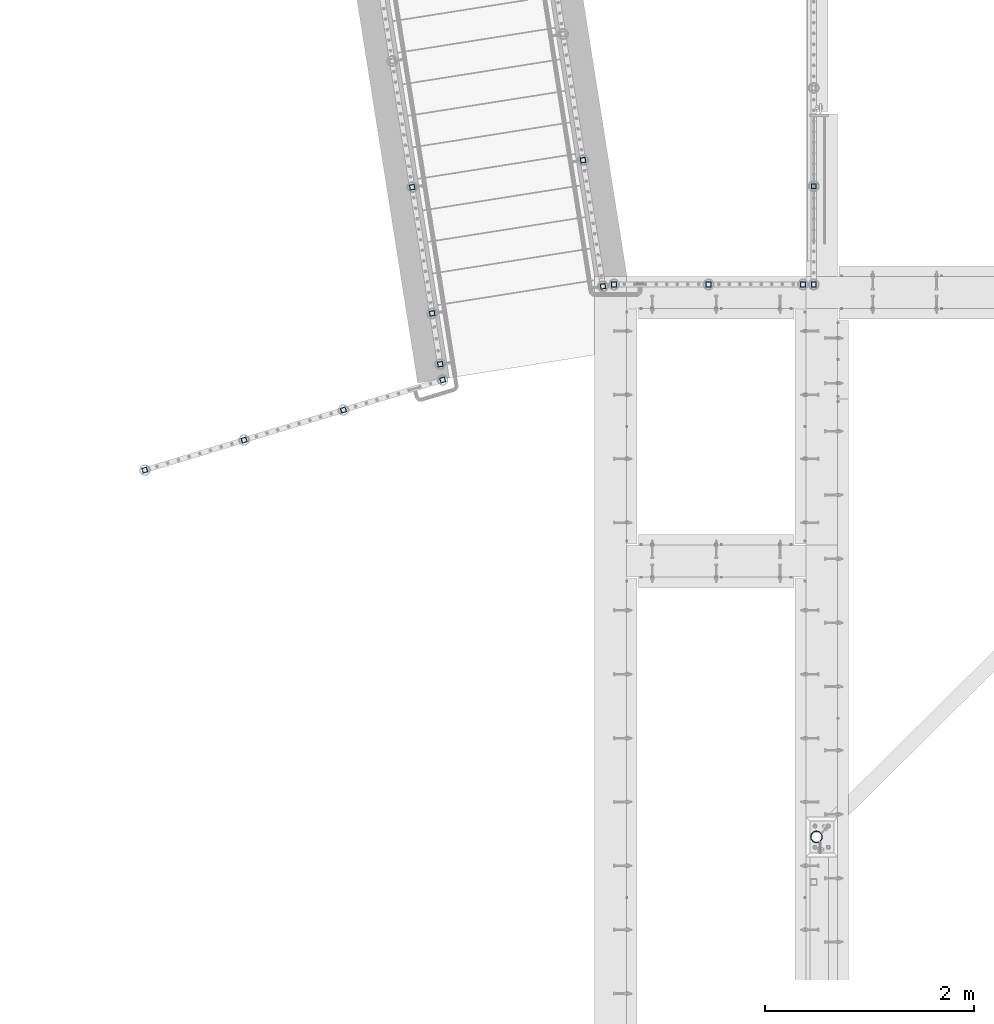
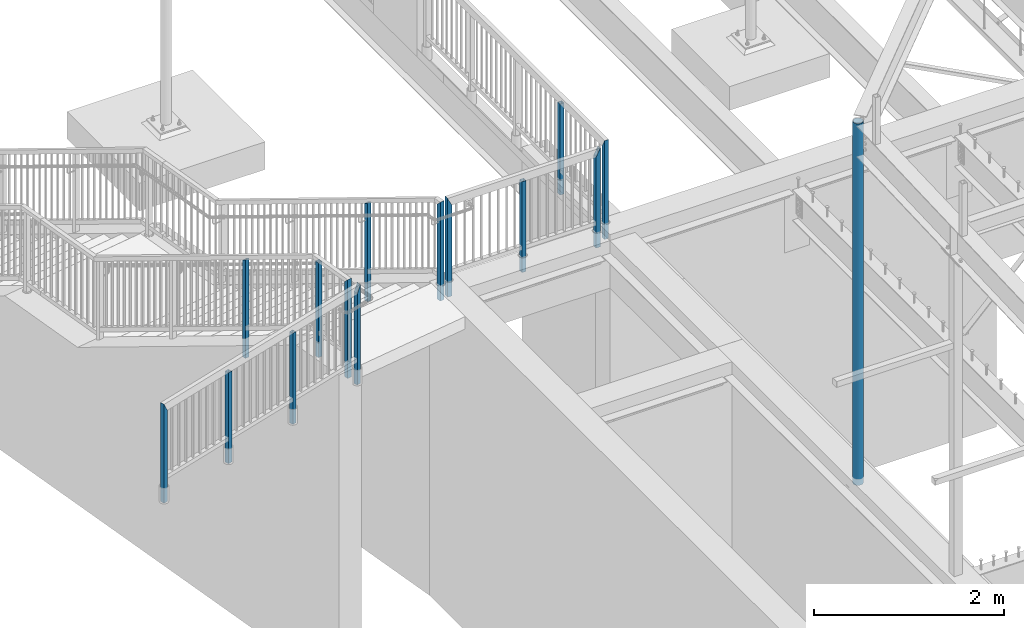
# One storey, part 124 of 975: 15 columns.
"""IFC2X3 building model written with IfcOpenShell, lengths in millimetres."""

import ifcopenshell
import ifcopenshell.guid

model = None  # the IFC model being written
_history = None  # IfcOwnerHistory: only IFC2X3 demands one
_inside = {}  # id of a spatial element -> (the spatial element, [elements in it])
_under = {}  # id of a project, library or spatial element -> (it, [spatial elements below it])
_declared = {}  # id of a project -> (the project, [libraries it declares])
_typed = {}  # id of a type object -> (the type object, [elements of that type])
_made_of = {}  # id of a material, layer set ... -> (it, [elements and type objects made of it])


def new_model(schema):
    """Start an empty IFC model of exactly this schema.

    Asked for "IFC4X3", IfcOpenShell would pick the latest addendum, in which some entities
    have other attributes; the version numbers below select the first issue.
    IFC2X3 requires an IfcOwnerHistory on every rooted entity: one is made here for all.
    """
    global model, _history
    if schema == "IFC4X3":
        model = ifcopenshell.file(schema_version=(4, 3, 0, 0))
    else:
        model = ifcopenshell.file(schema=schema)
    _inside.clear()
    _under.clear()
    _declared.clear()
    _typed.clear()
    _made_of.clear()
    _history = None
    if model.schema == "IFC2X3":
        org = make("IfcOrganization", Name="unknown")
        user = make(
            "IfcPersonAndOrganization",
            ThePerson=make("IfcPerson", FamilyName="unknown"),
            TheOrganization=org,
        )
        app = make(
            "IfcApplication",
            ApplicationDeveloper=org,
            Version="unknown",
            ApplicationFullName="unknown",
            ApplicationIdentifier="unknown",
        )
        _history = make(
            "IfcOwnerHistory",
            OwningUser=user,
            OwningApplication=app,
            ChangeAction="ADDED",
            CreationDate=0,
        )
    return model


def make(cls, **values):
    """One entity of the class cls with the attributes given. An attribute that is None is left unset."""
    return model.create_entity(
        cls, **{name: value for name, value in values.items() if value is not None}
    )


def rooted(cls, **values):
    """An entity with a GlobalId (a new one), such as an element, a storey or a relation."""
    return make(cls, GlobalId=ifcopenshell.guid.new(), OwnerHistory=_history, **values)


def si_unit(unit_type, name, prefix=None):
    """IfcSIUnit, for example si_unit("LENGTHUNIT", "METRE", prefix="MILLI")."""
    return make("IfcSIUnit", UnitType=unit_type, Prefix=prefix, Name=name)


def assignment(units):
    """IfcUnitAssignment: the units of a project."""
    return None if units is None else make("IfcUnitAssignment", Units=units)


def point(xyz):
    """IfcCartesianPoint."""
    return None if xyz is None else make("IfcCartesianPoint", Coordinates=xyz)


def direction(xyz):
    """IfcDirection."""
    return None if xyz is None else make("IfcDirection", DirectionRatios=xyz)


def frame(location, z_axis=None, x_axis=None):
    """IfcAxis2Placement3D, a coordinate frame: its origin and axes. An axis left out is left unset."""
    return make(
        "IfcAxis2Placement3D",
        Location=point(location),
        Axis=direction(z_axis),
        RefDirection=direction(x_axis),
    )


def origin_with_axes():
    """The frame at (0, 0, 0) with the z axis (0, 0, 1) and the x axis (1, 0, 0) written out."""
    return frame((0.0, 0.0, 0.0), z_axis=(0.0, 0.0, 1.0), x_axis=(1.0, 0.0, 0.0))


def place(relative_to, where):
    """IfcLocalPlacement: puts the frame where relative to a parent placement (None: the world)."""
    return make(
        "IfcLocalPlacement", PlacementRelTo=relative_to, RelativePlacement=where
    )


def context(
    kind, dimensions, precision=None, world=None, true_north=None, identifier=None
):
    """IfcGeometricRepresentationContext, for example the 3D "Model" context."""
    return make(
        "IfcGeometricRepresentationContext",
        ContextIdentifier=identifier,
        ContextType=kind,
        CoordinateSpaceDimension=dimensions,
        Precision=precision,
        WorldCoordinateSystem=world,
        TrueNorth=true_north,
    )


def subcontext(parent, identifier, kind, view, scale=None):
    """IfcGeometricRepresentationSubContext, for example "Body" below "Model"."""
    return make(
        "IfcGeometricRepresentationSubContext",
        ContextIdentifier=identifier,
        ContextType=kind,
        ParentContext=parent,
        TargetScale=scale,
        TargetView=view,
    )


def project(units=None, contexts=None):
    """IfcProject with its units and contexts."""
    return rooted(
        "IfcProject",
        Name="project",
        RepresentationContexts=contexts,
        UnitsInContext=assignment(units),
    )


def spatial(cls, under=None, at=None, **own):
    """A site, building, storey or space (cls), placed at a placement, below another one or the project."""
    s = rooted(cls, ObjectPlacement=at, **own)
    if under is not None:
        _under.setdefault(under.id(), (under, []))[1].append(s)
    return s


def faces_of(points, faces, orient=None, outer=None):
    """IfcFace entities. A face is a list of loops; a loop is a list of indices into points, from 0.

    orient and outer hold one flag for each loop. By default every Orientation is true, the
    first loop of a face is its IfcFaceOuterBound and the others are IfcFaceBound.
    """
    made = []
    for i, loops in enumerate(faces):
        bounds = []
        for j, loop in enumerate(loops):
            is_outer = j == 0 if outer is None else outer[i][j]
            bounds.append(
                make(
                    "IfcFaceOuterBound" if is_outer else "IfcFaceBound",
                    Bound=make("IfcPolyLoop", Polygon=[points[k] for k in loop]),
                    Orientation=True if orient is None else orient[i][j],
                )
            )
        made.append(make("IfcFace", Bounds=bounds))
    return made


def faceted_brep(points, faces, orient=None, outer=None, voids=None):
    """IfcFacetedBrep: a solid bounded by flat faces; with voids (closed shells), ...WithVoids."""
    shared = [point(p) for p in points]
    hull = make("IfcClosedShell", CfsFaces=faces_of(shared, faces, orient, outer))
    if voids is None:
        return make("IfcFacetedBrep", Outer=hull)
    return make(
        "IfcFacetedBrepWithVoids",
        Outer=hull,
        Voids=[
            make(cls, CfsFaces=faces_of(shared, fs, o, b)) for cls, fs, o, b in voids
        ],
    )


def shape(context_of_items, identifier, shape_type, items):
    """IfcShapeRepresentation: the items that make up one representation, for example the "Body"."""
    return make(
        "IfcShapeRepresentation",
        ContextOfItems=context_of_items,
        RepresentationIdentifier=identifier,
        RepresentationType=shape_type,
        Items=items,
    )


def material(Name=None, Category=None):
    """IfcMaterial."""
    return make("IfcMaterial", Name=Name, Category=Category)


def made_of(thing, what):
    """Note that an element or type object is made of a material, layer set ...; save() writes the relation."""
    if what is not None:
        _made_of.setdefault(what.id(), (what, []))[1].append(thing)
    return thing


def type_object(cls, material=None, **own):
    """A type object (cls), such as IfcWallType, which elements share."""
    return made_of(rooted(cls, **own), material)


def element(
    cls,
    number,
    at=None,
    inside=None,
    cuts=None,
    type_object=None,
    material=None,
    context=None,
    identifier="Body",
    shape_type=None,
    held_by="IfcProductDefinitionShape",
    body=None,
    shapes=None,
    **own,
):
    """One element of the class cls, such as IfcWall. Its Tag is "e" and its number.

    at: its placement. inside: the storey or other place that contains it. cuts: it is an
    opening in that element (IfcRelVoidsElement). A single representation is given by context,
    identifier, shape_type and body (its items); several are given by shapes. held_by: the class
    of the entity that holds the representations. save() writes the other relations.
    """
    e = rooted(cls, Tag="e%d" % number, ObjectPlacement=at, **own)
    if body is not None:
        shapes = [shape(context, identifier, shape_type, body)]
    if shapes is not None:
        e.Representation = make(held_by, Representations=shapes)
    if inside is not None:
        _inside.setdefault(inside.id(), (inside, []))[1].append(e)
    if cuts is not None:
        rooted(
            "IfcRelVoidsElement", RelatingBuildingElement=cuts, RelatedOpeningElement=e
        )
    if type_object is not None:
        _typed.setdefault(type_object.id(), (type_object, []))[1].append(e)
    return made_of(e, material)


def aggregate(whole, parts):
    """IfcRelAggregates: a whole, such as a stair, and the parts it consists of."""
    return rooted("IfcRelAggregates", RelatingObject=whole, RelatedObjects=parts)


def save(model, path):
    """Write the relations noted so far, then the file.

    IfcRelAggregates (storeys below a building ...), IfcRelContainedInSpatialStructure (elements
    in a storey), IfcRelDefinesByType, IfcRelAssociatesMaterial and IfcRelDeclares: one each for
    every whole, place, type object, material and project.
    """
    for whole, parts in _under.values():
        aggregate(whole, parts)
    for where, things in _inside.values():
        rooted(
            "IfcRelContainedInSpatialStructure",
            RelatedElements=things,
            RelatingStructure=where,
        )
    for kind, things in _typed.values():
        rooted("IfcRelDefinesByType", RelatedObjects=things, RelatingType=kind)
    for what, things in _made_of.values():
        rooted("IfcRelAssociatesMaterial", RelatedObjects=things, RelatingMaterial=what)
    for by, libraries in _declared.values():
        rooted("IfcRelDeclares", RelatingContext=by, RelatedDefinitions=libraries)
    model.write(path)


model = new_model("IFC2X3")

# Units and contexts
model_context = context("Model", 3, precision=1e-05, world=origin_with_axes())
body_context = subcontext(model_context, "Body", "Model", "MODEL_VIEW")
ifc_project = project(units=[si_unit("LENGTHUNIT", "METRE", prefix="MILLI"), si_unit("AREAUNIT", "SQUARE_METRE"), si_unit("VOLUMEUNIT", "CUBIC_METRE"), si_unit("MASSUNIT", "GRAM", prefix="KILO"), si_unit("TIMEUNIT", "SECOND"), si_unit("PLANEANGLEUNIT", "RADIAN"), si_unit("SOLIDANGLEUNIT", "STERADIAN"), si_unit("THERMODYNAMICTEMPERATUREUNIT", "DEGREE_CELSIUS"), si_unit("LUMINOUSINTENSITYUNIT", "LUMEN")], contexts=[model_context])

# Site, building, storey
site_placement = place(None, origin_with_axes())
site = spatial("IfcSite", under=ifc_project, at=site_placement, CompositionType="ELEMENT")
building_placement = place(site_placement, origin_with_axes())
building = spatial("IfcBuilding", under=site, at=building_placement, Name="Undefined", CompositionType="ELEMENT")
storey_placement = place(building_placement, origin_with_axes())
storey = spatial("IfcBuildingStorey", under=building, at=storey_placement, Name="Undefined", CompositionType="ELEMENT", Elevation=0.0)

# Columns
ifc_material_1 = material()
column_type_1 = type_object("IfcColumnType", Name="HSS2X2X.188_TUBES", PredefinedType="NOTDEFINED")
column_1_placement = place(storey_placement, frame((-1474.06692255113, 19910.997122319, 3835.40003518347), z_axis=(-0.987688340611262, -0.156434464938429, 0.0), x_axis=(0.0, 0.0, 1.0)))
element("IfcColumn", 1, at=column_1_placement, inside=storey, type_object=column_type_1, material=ifc_material_1, Name="HANDRAIL", ObjectType="HSS2X2X.188_TUBES", context=body_context, shape_type="Brep", body=[
    faceted_brep([(0.0, 20.6374999999753, -20.6375000000298), (0.0, -20.6375000000153, -20.6375000000153), (1265.23743975856, -20.6374999999971, -20.6374999999985), (1223.96244713993, 20.6374999999716, -20.6374999999923), (0.0, -20.6374999999825, 20.6375000000335), (1265.23744318539, -20.637499999968, 20.6374999999925), (0.0, 20.6375000000116, 20.6375000000189), (1223.96245056676, 20.6374999999971, 20.6374999999994), (0.0, 25.3999999999724, -25.4000000000342), (0.0, 25.400000000016, 25.4000000000196), (1219.19999999993, 25.400000000016, 25.4000000000196), (1219.19994759622, 25.3999999999651, -25.3999999999905), (0.0, -25.399999999976, 25.4000000000378), (1269.99994272909, -25.3999999999614, 25.3999999999912), (0.0, -25.400000000016, -25.4000000000196), (1269.99993851146, -25.3999999999978, -25.3999999999983)], [[[0, 1, 2, 3]], [[1, 4, 5, 2]], [[4, 6, 7, 5]], [[6, 0, 3, 7]], [[8, 9, 10, 11]], [[9, 12, 13, 10]], [[12, 14, 15, 13]], [[14, 8, 11, 15]], [[13, 15, 11, 10], [5, 7, 3, 2]], [[14, 12, 9, 8], [6, 4, 1, 0]]]),
])
column_2_placement = place(storey_placement, frame((-2398.41163327645, 19473.6740321977, 3835.40001692181), z_axis=(0.957137608769341, 0.289633557930203, -1.36013231895049e-08), x_axis=(0.0, 0.0, 1.0)))
element("IfcColumn", 2, at=column_2_placement, inside=storey, type_object=column_type_1, material=ifc_material_1, Name="HANDRAIL", ObjectType="HSS2X2X.188_TUBES", context=body_context, shape_type="Brep", body=[
    faceted_brep([(0.0, 20.6374999999753, -20.6375000000298), (0.0, -20.6375000000153, -20.6375000000153), (1168.39997128085, -20.6374999999789, -20.637499999993), (1168.39997128085, 20.6375000000371, -20.6374999999939), (0.0, -20.6374999999825, 20.6375000000335), (1168.40000013214, -20.6375000000371, 20.6375000000189), (0.0, 20.6375000000116, 20.6375000000189), (1168.40000013214, 20.6374999999789, 20.637500000018), (0.0, 25.3999999999724, -25.4000000000342), (0.0, 25.400000000016, 25.4000000000196), (1168.40000346113, 25.399999999976, 25.4000000000215), (1168.40000063294, 25.3999999999724, -25.4000000000342), (0.0, -25.399999999976, 25.4000000000378), (1168.40000346113, -25.4000000000451, 25.4000000000201), (0.0, -25.400000000016, -25.4000000000196), (1168.39999998263, -25.400000000016, -25.4000000000196)], [[[0, 1, 2, 3]], [[1, 4, 5, 2]], [[4, 6, 7, 5]], [[6, 0, 3, 7]], [[8, 9, 10, 11]], [[9, 12, 13, 10]], [[12, 14, 15, 13]], [[14, 8, 11, 15]], [[13, 15, 11, 10], [5, 7, 3, 2]], [[14, 12, 9, 8], [6, 4, 1, 0]]]),
])
column_3_placement = place(storey_placement, frame((-1450.2685998797, 19760.5767186958, 3835.40001060704), z_axis=(0.957137608769341, 0.289633557930203, -1.36013231895049e-08), x_axis=(0.0, 0.0, 1.0)))
element("IfcColumn", 3, at=column_3_placement, inside=storey, type_object=column_type_1, material=ifc_material_1, Name="HANDRAIL", ObjectType="HSS2X2X.188_TUBES", context=body_context, shape_type="Brep", body=[
    faceted_brep([(0.0, 20.6374999999753, -20.6375000000298), (0.0, -20.6375000000153, -20.6375000000153), (1177.92622909872, -20.6374999999789, -20.6374999999935), (1177.92497102682, 20.6375000000371, -20.6374999999944), (0.0, -20.6374999999825, 20.6375000000335), (1260.47497075396, -20.6375000000335, 20.6375000000207), (0.0, 20.6375000000116, 20.6375000000189), (1260.47371268207, 20.6374999999825, 20.6375000000189), (0.0, 25.3999999999724, -25.4000000000342), (0.0, 25.400000000016, 25.4000000000196), (1269.9984223263, 25.3999999999724, 25.4000000000215), (1168.40000063294, 25.3999999999724, -25.4000000000342), (0.0, -25.399999999976, 25.4000000000378), (1269.99994272909, -25.3999999999614, 25.3999999999912), (0.0, -25.400000000016, -25.4000000000196), (1168.40151945449, -25.3999999999687, -25.399999999996)], [[[0, 1, 2, 3]], [[1, 4, 5, 2]], [[4, 6, 7, 5]], [[6, 0, 3, 7]], [[8, 9, 10, 11]], [[9, 12, 13, 10]], [[12, 14, 15, 13]], [[14, 8, 11, 15]], [[13, 15, 11, 10], [5, 7, 3, 2]], [[14, 12, 9, 8], [6, 4, 1, 0]]]),
])
column_4_placement = place(storey_placement, frame((-3346.54068504426, 19186.7251494806, 3835.40001593121), z_axis=(0.957137608769341, 0.289633557930203, -1.36013231895049e-08), x_axis=(0.0, 0.0, 1.0)))
element("IfcColumn", 4, at=column_4_placement, inside=storey, type_object=column_type_1, material=ifc_material_1, Name="HANDRAIL", ObjectType="HSS2X2X.188_TUBES", context=body_context, shape_type="Brep", body=[
    faceted_brep([(0.0, 20.6374999999753, -20.6375000000298), (0.0, -20.6375000000153, -20.6375000000153), (1168.39997128085, -20.6374999999789, -20.637499999993), (1168.39997128085, 20.6375000000371, -20.6374999999939), (0.0, -20.6374999999825, 20.6375000000335), (1168.40000013214, -20.6375000000371, 20.6375000000189), (0.0, 20.6375000000116, 20.6375000000189), (1168.40000013214, 20.6374999999789, 20.637500000018), (0.0, 25.3999999999724, -25.4000000000342), (0.0, 25.400000000016, 25.4000000000196), (1168.40000346113, 25.399999999976, 25.4000000000215), (1168.40000063294, 25.3999999999724, -25.4000000000342), (0.0, -25.399999999976, 25.4000000000378), (1168.40000346113, -25.4000000000451, 25.4000000000201), (0.0, -25.400000000016, -25.4000000000196), (1168.39999998263, -25.400000000016, -25.4000000000196)], [[[0, 1, 2, 3]], [[1, 4, 5, 2]], [[4, 6, 7, 5]], [[6, 0, 3, 7]], [[8, 9, 10, 11]], [[9, 12, 13, 10]], [[12, 14, 15, 13]], [[14, 8, 11, 15]], [[13, 15, 11, 10], [5, 7, 3, 2]], [[14, 12, 9, 8], [6, 4, 1, 0]]]),
])
column_5_placement = place(storey_placement, frame((-4294.69060420685, 18899.8452153737, 3835.40002182394), z_axis=(0.957137608769341, 0.289633557930203, -1.36013231895049e-08), x_axis=(0.0, 0.0, 1.0)))
element("IfcColumn", 5, at=column_5_placement, inside=storey, type_object=column_type_1, material=ifc_material_1, Name="HANDRAIL", ObjectType="HSS2X2X.188_TUBES", context=body_context, shape_type="Brep", body=[
    faceted_brep([(0.0, 20.6374999999753, -20.6375000000298), (0.0, -20.6375000000153, -20.6375000000153), (1260.4737225784, -20.6374999994368, -20.6375000001688), (1260.47498063661, 20.6375000005683, -20.6375000001867), (0.0, -20.6374999999825, 20.6375000000335), (1177.92498039691, -20.6374999995278, 20.6374999998725), (0.0, 20.6375000000116, 20.6375000000189), (1177.92623845512, 20.6375000004809, 20.6374999998552), (0.0, 25.3999999999724, -25.4000000000342), (0.0, 25.400000000016, 25.4000000000196), (1168.40152874859, 25.4000000004708, 25.399999999858), (1269.99998066427, 25.4000000005799, -25.4000000001936), (0.0, -25.399999999976, 25.4000000000378), (1168.40000346113, -25.4000000000451, 25.4000000000201), (0.0, -25.400000000016, -25.4000000000196), (1269.99843228494, -25.3999999994303, -25.4000000001722)], [[[0, 1, 2, 3]], [[1, 4, 5, 2]], [[4, 6, 7, 5]], [[6, 0, 3, 7]], [[8, 9, 10, 11]], [[9, 12, 13, 10]], [[12, 14, 15, 13]], [[14, 8, 11, 15]], [[13, 15, 11, 10], [5, 7, 3, 2]], [[14, 12, 9, 8], [6, 4, 1, 0]]]),
])
column_6_placement = place(storey_placement, frame((1990.12300113828, 20672.4250004, 3835.40001060704), z_axis=(1.0, 0.0, 0.0), x_axis=(0.0, 0.0, 1.0)))
element("IfcColumn", 6, at=column_6_placement, inside=storey, type_object=column_type_1, material=ifc_material_1, Name="HANDRAIL", ObjectType="HSS2X2X.188_TUBES", context=body_context, shape_type="Brep", body=[
    faceted_brep([(0.0, 20.6374999999753, -20.6375000000298), (0.0, -20.6375000000153, -20.6375000000153), (1177.92497225151, -20.6375000000007, -20.6374999999875), (1177.92497102682, 20.6375000000371, -20.6374999999944), (0.0, -20.6374999999825, 20.6375000000335), (1260.47497075396, -20.6375000000335, 20.6375000000207), (0.0, 20.6375000000116, 20.6375000000189), (1260.47497199207, 20.6375000000007, 20.6375000000132), (0.0, 25.3999999999724, -25.4000000000342), (0.0, 25.400000000016, 25.4000000000196), (1269.99997196214, 25.4000000000015, 25.4000000000135), (1168.40000063294, 25.3999999999724, -25.4000000000342), (0.0, -25.399999999976, 25.4000000000378), (1269.99994272909, -25.3999999999614, 25.3999999999912), (0.0, -25.400000000016, -25.4000000000196), (1168.39999998263, -25.400000000016, -25.4000000000196)], [[[0, 1, 2, 3]], [[1, 4, 5, 2]], [[4, 6, 7, 5]], [[6, 0, 3, 7]], [[8, 9, 10, 11]], [[9, 12, 13, 10]], [[12, 14, 15, 13]], [[14, 8, 11, 15]], [[13, 15, 11, 10], [5, 7, 3, 2]], [[14, 12, 9, 8], [6, 4, 1, 0]]]),
])
column_7_placement = place(storey_placement, frame((1088.20566786924, 20672.3889673828, 3835.40001649977), z_axis=(1.0, 0.0, 0.0), x_axis=(0.0, 0.0, 1.0)))
element("IfcColumn", 7, at=column_7_placement, inside=storey, type_object=column_type_1, material=ifc_material_1, Name="HANDRAIL", ObjectType="HSS2X2X.188_TUBES", context=body_context, shape_type="Brep", body=[
    faceted_brep([(0.0, 20.6374999999753, -20.6375000000298), (0.0, -20.6375000000153, -20.6375000000153), (1168.39997128085, -20.6374999999789, -20.637499999993), (1168.39997128085, 20.6375000000371, -20.6374999999939), (0.0, -20.6374999999825, 20.6375000000335), (1168.40000013214, -20.6375000000371, 20.6375000000189), (0.0, 20.6375000000116, 20.6375000000189), (1168.40000013214, 20.6374999999789, 20.637500000018), (0.0, 25.3999999999724, -25.4000000000342), (0.0, 25.400000000016, 25.4000000000196), (1168.40000346113, 25.399999999976, 25.4000000000215), (1168.40000063294, 25.3999999999724, -25.4000000000342), (0.0, -25.399999999976, 25.4000000000378), (1168.40000346113, -25.4000000000451, 25.4000000000201), (0.0, -25.400000000016, -25.4000000000196), (1168.39999998263, -25.400000000016, -25.4000000000196)], [[[0, 1, 2, 3]], [[1, 4, 5, 2]], [[4, 6, 7, 5]], [[6, 0, 3, 7]], [[8, 9, 10, 11]], [[9, 12, 13, 10]], [[12, 14, 15, 13]], [[14, 8, 11, 15]], [[13, 15, 11, 10], [5, 7, 3, 2]], [[14, 12, 9, 8], [6, 4, 1, 0]]]),
])
column_8_placement = place(storey_placement, frame((186.288333380988, 20672.4249713359, 3835.40001649977), z_axis=(1.0, 0.0, 0.0), x_axis=(0.0, 0.0, 1.0)))
element("IfcColumn", 8, at=column_8_placement, inside=storey, type_object=column_type_1, material=ifc_material_1, Name="HANDRAIL", ObjectType="HSS2X2X.188_TUBES", context=body_context, shape_type="Brep", body=[
    faceted_brep([(0.0, 20.6374999999753, -20.6375000000298), (0.0, -20.6375000000153, -20.6375000000153), (1260.4749795328, -20.6374999994405, -20.6375), (1260.47498063661, 20.6375000005683, -20.6375000001867), (0.0, -20.6374999999825, 20.6375000000335), (1177.92498039691, -20.6374999995278, 20.6374999998725), (0.0, 20.6375000000116, 20.6375000000189), (1177.92498168426, 20.637500000521, 20.6375), (0.0, 25.3999999999724, -25.4000000000342), (0.0, 25.400000000016, 25.4000000000196), (1168.40000346113, 25.399999999976, 25.4000000000215), (1269.99998066427, 25.4000000005799, -25.4000000001936), (0.0, -25.399999999976, 25.4000000000378), (1168.40000346113, -25.4000000000451, 25.4000000000201), (0.0, -25.400000000016, -25.4000000000196), (1269.99993851146, -25.3999999999978, -25.3999999999983)], [[[0, 1, 2, 3]], [[1, 4, 5, 2]], [[4, 6, 7, 5]], [[6, 0, 3, 7]], [[8, 9, 10, 11]], [[9, 12, 13, 10]], [[12, 14, 15, 13]], [[14, 8, 11, 15]], [[13, 15, 11, 10], [5, 7, 3, 2]], [[14, 12, 9, 8], [6, 4, 1, 0]]]),
])
column_9_placement = place(storey_placement, frame((2091.7784545645, 21610.6326741956, 3911.60001429354), z_axis=(0.0, 1.0, 0.0), x_axis=(0.0, 0.0, 1.0)))
element("IfcColumn", 9, at=column_9_placement, inside=storey, type_object=column_type_1, material=ifc_material_1, Name="HANDRAIL", ObjectType="HSS2X2X.188_TUBES", context=body_context, shape_type="Brep", body=[
    faceted_brep([(0.0, 20.6374999999753, -20.6375000000298), (0.0, -20.6375000000153, -20.6375000000153), (1168.39997128085, -20.6374999999789, -20.637499999993), (1168.39997128085, 20.6375000000371, -20.6374999999939), (0.0, -20.6374999999825, 20.6375000000335), (1168.40000013214, -20.6375000000371, 20.6375000000189), (0.0, 20.6375000000116, 20.6375000000189), (1168.40000013214, 20.6374999999789, 20.637500000018), (0.0, 25.3999999999724, -25.4000000000342), (0.0, 25.400000000016, 25.4000000000196), (1168.40000346113, 25.399999999976, 25.4000000000215), (1168.40000063294, 25.3999999999724, -25.4000000000342), (0.0, -25.399999999976, 25.4000000000378), (1168.40000346113, -25.4000000000451, 25.4000000000201), (0.0, -25.400000000016, -25.4000000000196), (1168.39999998263, -25.400000000016, -25.4000000000196)], [[[0, 1, 2, 3]], [[1, 4, 5, 2]], [[4, 6, 7, 5]], [[6, 0, 3, 7]], [[8, 9, 10, 11]], [[9, 12, 13, 10]], [[12, 14, 15, 13]], [[14, 8, 11, 15]], [[13, 15, 11, 10], [5, 7, 3, 2]], [[14, 12, 9, 8], [6, 4, 1, 0]]]),
])
column_10_placement = place(storey_placement, frame((2091.72299802514, 20672.4207164027, 3911.60001178547), z_axis=(0.0, 1.0, 0.0), x_axis=(0.0, 0.0, 1.0)))
element("IfcColumn", 10, at=column_10_placement, inside=storey, type_object=column_type_1, material=ifc_material_1, Name="HANDRAIL", ObjectType="HSS2X2X.188_TUBES", context=body_context, shape_type="Brep", body=[
    faceted_brep([(0.0, 20.6374999999753, -20.6375000000298), (0.0, -20.6375000000153, -20.6375000000153), (1260.4749795328, -20.6374999994405, -20.6375), (1260.46929340773, 20.6374999999866, -20.6375000000007), (0.0, -20.6374999999825, 20.6375000000335), (1177.93068300678, -20.6375000000126, 20.6375000000007), (0.0, 20.6375000000116, 20.6375000000189), (1177.92498168426, 20.637500000521, 20.6375), (0.0, 25.3999999999724, -25.4000000000342), (0.0, 25.400000000016, 25.4000000000196), (1168.40000346113, 25.399999999976, 25.4000000000215), (1269.99297922323, 25.3999999999864, -25.4000000000015), (0.0, -25.399999999976, 25.4000000000378), (1168.40699719129, -25.4000000000124, 25.4000000000015), (0.0, -25.400000000016, -25.4000000000196), (1269.99993851146, -25.3999999999978, -25.3999999999983)], [[[0, 1, 2, 3]], [[1, 4, 5, 2]], [[4, 6, 7, 5]], [[6, 0, 3, 7]], [[8, 9, 10, 11]], [[9, 12, 13, 10]], [[12, 14, 15, 13]], [[14, 8, 11, 15]], [[13, 15, 11, 10], [5, 7, 3, 2]], [[14, 12, 9, 8], [6, 4, 1, 0]]]),
])
column_11_placement = place(storey_placement, frame((-1550.95813857823, 20396.3052477243, 3835.40003518347), z_axis=(-0.987688340611262, -0.156434464938429, 0.0), x_axis=(0.0, 0.0, 1.0)))
element("IfcColumn", 11, at=column_11_placement, inside=storey, type_object=column_type_1, material=ifc_material_1, Name="HANDRAIL", ObjectType="HSS2X2X.188_TUBES", context=body_context, shape_type="Brep", body=[
    faceted_brep([(0.0, 20.6374999999753, -20.6375000000298), (0.0, -20.6375000000153, -20.6375000000153), (1219.2, -20.6374999999971, -20.6375000000298), (1219.2, 20.6374999999844, -20.6374999999716), (0.0, -20.6374999999825, 20.6375000000335), (1219.2, -20.6374999999898, 20.6374999999825), (0.0, 20.6375000000116, 20.6375000000189), (1219.2, 20.6374999999916, 20.6375000000407), (0.0, 25.3999999999724, -25.4000000000342), (0.0, 25.400000000016, 25.4000000000196), (1219.19999999993, 25.400000000016, 25.4000000000196), (1219.19994759622, 25.3999999999651, -25.3999999999905), (0.0, -25.399999999976, 25.4000000000378), (1219.19999934962, -25.399999999976, 25.4000000000378), (0.0, -25.400000000016, -25.4000000000196), (1219.2, -25.399999999996, -25.4000000000378)], [[[0, 1, 2, 3]], [[1, 4, 5, 2]], [[4, 6, 7, 5]], [[6, 0, 3, 7]], [[8, 9, 10, 11]], [[9, 12, 13, 10]], [[12, 14, 15, 13]], [[14, 8, 11, 15]], [[13, 15, 11, 10], [5, 7, 3, 2]], [[14, 12, 9, 8], [6, 4, 1, 0]]]),
])
column_12_placement = place(storey_placement, frame((-1741.68308965817, 21600.4948580056, 3162.29994931268), z_axis=(-0.987688340611262, -0.156434464938429, 0.0), x_axis=(0.0, 0.0, 1.0)))
element("IfcColumn", 12, at=column_12_placement, inside=storey, type_object=column_type_1, material=ifc_material_1, Name="HANDRAIL", ObjectType="HSS2X2X.188_TUBES", context=body_context, shape_type="Brep", body=[
    faceted_brep([(0.0, 20.6374999999753, -20.6375000000298), (0.0, -20.6375000000153, -20.6375000000153), (1265.43479462161, -20.6375000017724, -20.6374999997315), (1242.64755467623, 20.6374999982327, -20.6374999997299), (0.0, -20.6374999999825, 20.6375000000335), (1265.43479458883, -20.6375000017433, 20.6375000002599), (0.0, 20.6375000000116, 20.6375000000189), (1242.64755464344, 20.6374999982581, 20.6375000002615), (0.0, 25.3999999999724, -25.4000000000342), (0.0, 25.400000000016, 25.4000000000196), (1240.01825772289, 25.3999999982625, 25.4000000002604), (1240.01825776323, 25.3999999982298, -25.3999999997288), (0.0, -25.399999999976, 25.4000000000378), (1268.06409150182, -25.4000000017368, 25.4000000002588), (0.0, -25.400000000016, -25.4000000000196), (1268.06409154217, -25.4000000017732, -25.3999999997304)], [[[0, 1, 2, 3]], [[1, 4, 5, 2]], [[4, 6, 7, 5]], [[6, 0, 3, 7]], [[8, 9, 10, 11]], [[9, 12, 13, 10]], [[12, 14, 15, 13]], [[14, 8, 11, 15]], [[13, 15, 11, 10], [5, 7, 3, 2]], [[14, 12, 9, 8], [6, 4, 1, 0]]]),
])
column_13_placement = place(storey_placement, frame((79.9087505992718, 20654.609187241, 3835.40003518347), z_axis=(0.987688352468583, 0.156434390074216, -6.09999983468464e-08), x_axis=(0.0, 0.0, 1.0)))
element("IfcColumn", 13, at=column_13_placement, inside=storey, type_object=column_type_1, material=ifc_material_1, Name="HANDRAIL", ObjectType="HSS2X2X.188_TUBES", context=body_context, shape_type="Brep", body=[
    faceted_brep([(0.0, 20.6374999999753, -20.6375000000298), (0.0, -20.6375000000153, -20.6375000000153), (1223.96249999353, -20.6374999999753, -20.6375000000226), (1265.23739300282, 20.637499999968, -20.6374999999948), (0.0, -20.6374999999825, 20.6375000000335), (1223.96250000265, -20.6375000000207, 20.6375000000371), (0.0, 20.6375000000116, 20.6375000000189), (1265.23743015489, 20.6374999999971, 20.6375000000003), (0.0, 25.3999999999724, -25.4000000000342), (0.0, 25.400000000016, 25.4000000000196), (1269.99997196214, 25.4000000000015, 25.4000000000135), (1269.99988096686, 25.3999999999614, -25.3999999999937), (0.0, -25.399999999976, 25.4000000000378), (1219.19999934962, -25.399999999976, 25.4000000000378), (0.0, -25.400000000016, -25.4000000000196), (1219.2, -25.399999999996, -25.4000000000378)], [[[0, 1, 2, 3]], [[1, 4, 5, 2]], [[4, 6, 7, 5]], [[6, 0, 3, 7]], [[8, 9, 10, 11]], [[9, 12, 13, 10]], [[12, 14, 15, 13]], [[14, 8, 11, 15]], [[13, 15, 11, 10], [5, 7, 3, 2]], [[14, 12, 9, 8], [6, 4, 1, 0]]]),
])
column_14_placement = place(storey_placement, frame((-110.816096746242, 21858.7988205052, 3162.29994931268), z_axis=(0.987688352468583, 0.156434390074216, -6.09999983468464e-08), x_axis=(0.0, 0.0, 1.0)))
element("IfcColumn", 14, at=column_14_placement, inside=storey, type_object=column_type_1, material=ifc_material_1, Name="HANDRAIL", ObjectType="HSS2X2X.188_TUBES", context=body_context, shape_type="Brep", body=[
    faceted_brep([(0.0, 20.6374999999753, -20.6375000000298), (0.0, -20.6375000000153, -20.6375000000153), (1242.64756997557, -20.6374999999971, -20.6375000000003), (1265.43481035084, 20.637499999968, -20.6374999999953), (0.0, -20.6374999999825, 20.6375000000335), (1242.64756991491, -20.637499999968, 20.6374999999953), (0.0, 20.6375000000116, 20.6375000000189), (1265.43481029018, 20.6374999999935, 20.6375000000003), (0.0, 25.3999999999724, -25.4000000000342), (0.0, 25.400000000016, 25.4000000000196), (1268.06410724956, 25.3999999999978, 25.4000000000001), (1268.06410732422, 25.3999999999578, -25.3999999999937), (0.0, -25.399999999976, 25.4000000000378), (1240.01827294153, -25.3999999999614, 25.3999999999937), (0.0, -25.400000000016, -25.4000000000196), (1240.01827301619, -25.4000000000015, -25.4000000000005)], [[[0, 1, 2, 3]], [[1, 4, 5, 2]], [[4, 6, 7, 5]], [[6, 0, 3, 7]], [[8, 9, 10, 11]], [[9, 12, 13, 10]], [[12, 14, 15, 13]], [[14, 8, 11, 15]], [[13, 15, 11, 10], [5, 7, 3, 2]], [[14, 12, 9, 8], [6, 4, 1, 0]]]),
])
ifc_material_2 = material(Name="STEEL/A53")
column_type_2 = type_object("IfcColumnType", Name="PIPE4STD", PredefinedType="NOTDEFINED")
column_15_placement = place(storey_placement, frame((2117.725, 15398.75, 3937.0), z_axis=(0.0, 1.0, 0.0), x_axis=(0.0, 0.0, 1.0)))
element("IfcColumn", 15, at=column_15_placement, inside=storey, type_object=column_type_2, material=ifc_material_2, Name="COLUMN", ObjectType="PIPE4STD", context=body_context, shape_type="Brep", body=[
    faceted_brep([(19.0500000000025, -51.1301999999996, 0.0), (19.0500000000025, -48.6277098894743, 15.8001007257917), (4664.07499999934, -48.6277098894743, 15.8001007257899), (4664.07499999934, -51.1302000000001, 0.0), (19.0500000000025, -41.3652007257897, 30.0535775067656), (4664.07499999934, -41.3652007257901, 30.0535775067638), (19.0500000000025, -30.0535775067647, 41.3652007257915), (4664.07499999934, -30.0535775067647, 41.3652007257897), (19.0500000000025, -15.8001007257899, 48.6277098894752), (4664.07499999934, -15.8001007257899, 48.6277098894752), (19.0500000000025, 0.0, 51.1301999999996), (4664.07499999934, 0.0, 51.1301999999996), (19.0500000000025, 15.8001007257899, 48.6277098894752), (4664.07499999934, 15.8001007257899, 48.6277098894752), (19.0500000000025, 30.0535775067647, 41.3652007257915), (4664.07499999934, 30.0535775067647, 41.3652007257897), (19.0500000000025, 41.3652007257897, 30.0535775067656), (4664.07499999934, 41.3652007257901, 30.0535775067638), (19.0500000000025, 48.6277098894743, 15.8001007257917), (4664.07499999934, 48.6277098894743, 15.8001007257899), (19.0500000000025, 51.1301999999996, 0.0), (4664.07499999934, 51.1302000000001, 0.0), (19.0500000000025, 48.6277098894743, -15.8001007257917), (4664.07499999934, 48.6277098894743, -15.8001007257899), (19.0500000000025, 41.3652007257897, -30.0535775067656), (4664.07499999934, 41.3652007257901, -30.0535775067638), (19.0500000000025, 30.0535775067647, -41.3652007257915), (4664.07499999934, 30.0535775067647, -41.3652007257897), (19.0500000000025, 15.8001007257899, -48.6277098894752), (4664.07499999934, 15.8001007257899, -48.6277098894752), (19.0500000000025, 0.0, -51.1301999999996), (4664.07499999934, 0.0, -51.1301999999996), (19.0500000000025, -15.8001007257899, -48.6277098894752), (4664.07499999934, -15.8001007257899, -48.6277098894752), (19.0500000000025, -30.0535775067647, -41.3652007257915), (4664.07499999934, -30.0535775067647, -41.3652007257897), (19.0500000000025, -41.3652007257897, -30.0535775067656), (4664.07499999934, -41.3652007257901, -30.0535775067638), (19.0500000000025, -48.6277098894743, -15.8001007257917), (4664.07499999934, -48.6277098894743, -15.8001007257899), (19.0500000000025, -57.1499999999996, 0.0), (19.0500000000025, -54.3528799062678, -17.6603212285299), (4664.07499999934, -54.3528799062678, -17.6603212285281), (4664.07499999934, -57.1500000000001, 0.0), (19.0500000000025, -46.2353212285279, -33.5919271685161), (4664.07499999934, -46.2353212285284, -33.5919271685143), (19.0500000000025, -33.5919271685152, -46.235321228527), (4664.07499999934, -33.5919271685148, -46.2353212285288), (19.0500000000025, -17.6603212285281, -54.3528799062697), (4664.07499999934, -17.6603212285281, -54.3528799062678), (19.0500000000025, 0.0, -57.1500000000015), (4664.07499999934, 0.0, -57.1499999999996), (19.0500000000025, 17.6603212285281, -54.3528799062697), (4664.07499999934, 17.6603212285281, -54.3528799062678), (19.0500000000025, 33.5919271685152, -46.235321228527), (4664.07499999934, 33.5919271685148, -46.2353212285288), (19.0500000000025, 46.2353212285279, -33.5919271685161), (4664.07499999934, 46.2353212285284, -33.5919271685143), (19.0500000000025, 54.3528799062678, -17.6603212285299), (4664.07499999934, 54.3528799062678, -17.6603212285281), (19.0500000000025, 57.1499999999996, 0.0), (4664.07499999934, 57.1500000000001, 0.0), (19.0500000000025, 54.3528799062678, 17.6603212285299), (4664.07499999934, 54.3528799062678, 17.6603212285281), (19.0500000000025, 46.2353212285279, 33.5919271685161), (4664.07499999934, 46.2353212285284, 33.5919271685143), (19.0500000000025, 33.5919271685152, 46.235321228527), (4664.07499999934, 33.5919271685148, 46.2353212285288), (19.0500000000025, 17.6603212285281, 54.3528799062697), (4664.07499999934, 17.6603212285281, 54.3528799062678), (19.0500000000025, 0.0, 57.1500000000015), (4664.07499999934, 0.0, 57.1499999999996), (19.0500000000025, -17.6603212285281, 54.3528799062697), (4664.07499999934, -17.6603212285281, 54.3528799062678), (19.0500000000025, -33.5919271685152, 46.235321228527), (4664.07499999934, -33.5919271685148, 46.2353212285288), (19.0500000000025, -46.2353212285279, 33.5919271685161), (4664.07499999934, -46.2353212285284, 33.5919271685143), (19.0500000000025, -54.3528799062678, 17.6603212285299), (4664.07499999934, -54.3528799062678, 17.6603212285281)], [[[0, 1, 2, 3]], [[1, 4, 5, 2]], [[4, 6, 7, 5]], [[6, 8, 9, 7]], [[8, 10, 11, 9]], [[10, 12, 13, 11]], [[12, 14, 15, 13]], [[14, 16, 17, 15]], [[16, 18, 19, 17]], [[18, 20, 21, 19]], [[20, 22, 23, 21]], [[22, 24, 25, 23]], [[24, 26, 27, 25]], [[26, 28, 29, 27]], [[28, 30, 31, 29]], [[30, 32, 33, 31]], [[32, 34, 35, 33]], [[34, 36, 37, 35]], [[36, 38, 39, 37]], [[38, 0, 3, 39]], [[40, 41, 42, 43]], [[41, 44, 45, 42]], [[44, 46, 47, 45]], [[46, 48, 49, 47]], [[48, 50, 51, 49]], [[50, 52, 53, 51]], [[52, 54, 55, 53]], [[54, 56, 57, 55]], [[56, 58, 59, 57]], [[58, 60, 61, 59]], [[60, 62, 63, 61]], [[62, 64, 65, 63]], [[64, 66, 67, 65]], [[66, 68, 69, 67]], [[68, 70, 71, 69]], [[70, 72, 73, 71]], [[72, 74, 75, 73]], [[74, 76, 77, 75]], [[76, 78, 79, 77]], [[78, 40, 43, 79]], [[45, 47, 49, 51, 53, 55, 57, 59, 61, 63, 65, 67, 69, 71, 73, 75, 77, 79, 43, 42], [5, 7, 9, 11, 13, 15, 17, 19, 21, 23, 25, 27, 29, 31, 33, 35, 37, 39, 3, 2]], [[78, 76, 74, 72, 70, 68, 66, 64, 62, 60, 58, 56, 54, 52, 50, 48, 46, 44, 41, 40], [38, 36, 34, 32, 30, 28, 26, 24, 22, 20, 18, 16, 14, 12, 10, 8, 6, 4, 1, 0]]]),
])

save(model, "model.ifc")
